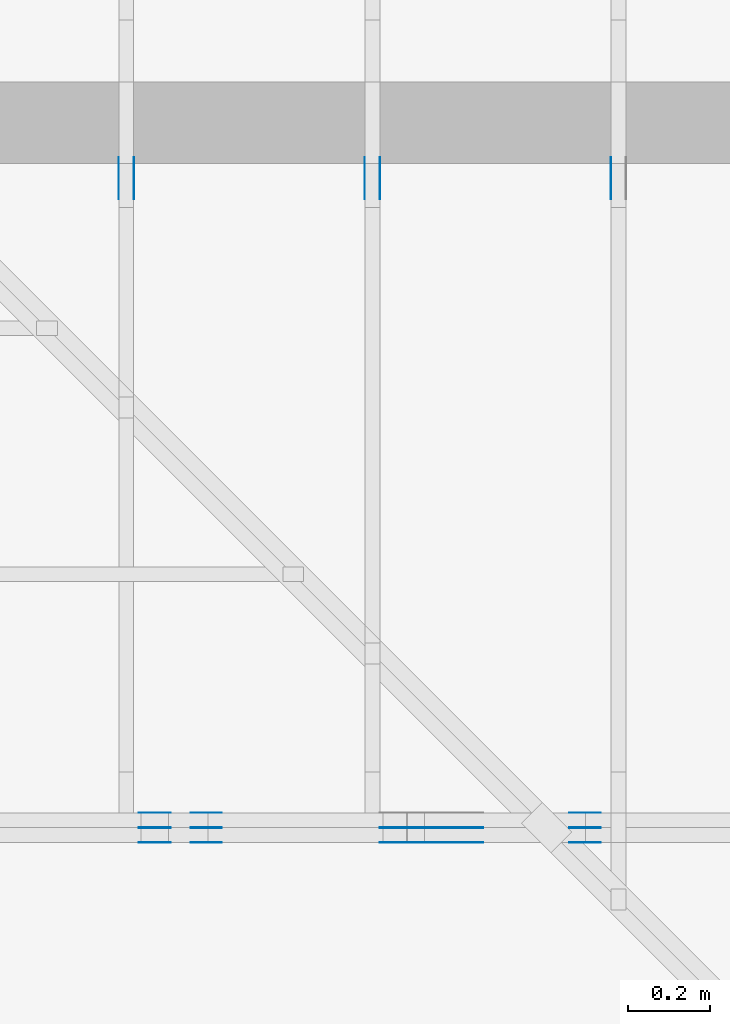
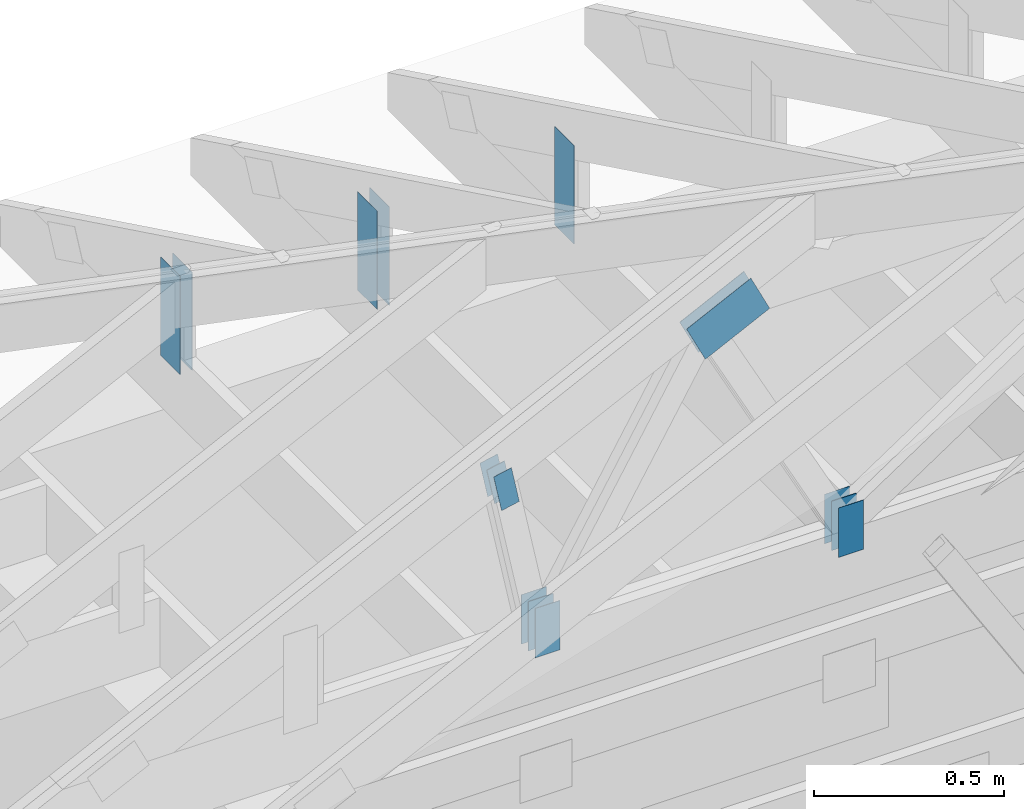
# One storey, part 109 of 159: 20 plates, 4 elements without a shape of their own.
"""IFC2X3 building model written with IfcOpenShell, lengths in millimetres."""

from ifc_helpers import new_model, si_unit, frame, origin, origin_with_axes, origin_2d, place, context, project, spatial, faceted_brep, element, aggregate, save


model = new_model("IFC2X3")

# Units and contexts
model_context = context("Model", 3, precision=1e-05, world=origin())
plan_context = context("Plan", 2, precision=1e-05, world=origin_2d())
ifc_project = project(units=[si_unit("LENGTHUNIT", "METRE", prefix="MILLI"), si_unit("AREAUNIT", "SQUARE_METRE"), si_unit("VOLUMEUNIT", "CUBIC_METRE"), si_unit("SOLIDANGLEUNIT", "STERADIAN"), si_unit("PLANEANGLEUNIT", "RADIAN"), si_unit("MASSUNIT", "GRAM"), si_unit("TIMEUNIT", "SECOND"), si_unit("THERMODYNAMICTEMPERATUREUNIT", "DEGREE_CELSIUS"), si_unit("LUMINOUSINTENSITYUNIT", "LUMEN")], contexts=[model_context, plan_context])

# Site, building, storey
site_placement = place(None, origin_with_axes())
site = spatial("IfcSite", under=ifc_project, at=site_placement, CompositionType="ELEMENT")
building_placement = place(site_placement, origin_with_axes())
building = spatial("IfcBuilding", under=site, at=building_placement, Name="Plan 1", CompositionType="ELEMENT")
storey_placement = place(building_placement, origin_with_axes())
storey = spatial("IfcBuildingStorey", under=building, at=storey_placement, Name="Etasje 1", CompositionType="ELEMENT", Elevation=0.0)

# Assembly, plates
assembly_1_placement = place(storey_placement, frame((19200.01266310149, 11417.999978540158, 0.0), z_axis=(1.2246063538223773e-16, 1.0, 6.123031769111886e-17), x_axis=(-1.0, 1.2246063538223773e-16, 0.0)))
assembly_1 = element("IfcElementAssembly", 1, at=assembly_1_placement, inside=storey, Name="V9 (1)", AssemblyPlace="FACTORY", PredefinedType="TRUSS")
plate_1_placement = place(assembly_1_placement, frame((7089.08254927267, 1040.5283812914454, -37.0), z_axis=(0.0, 0.0, 1.0), x_axis=(-0.8987940462991675, 0.4383711467890765, 0.0)))
plate_1 = element("IfcPlate", 2, at=plate_1_placement, Name="GNT100S 130x218", context=model_context, shape_type="Brep", body=[
    faceted_brep([(217.99994580165003, 130.0000591753469, 1.0), (4.001814977527829e-05, 130.0000591753469, 1.0), (0.0, 6.784529341530288e-05, 1.0), (217.999932539552, 6.784529341530288e-05, 1.0), (4.001814977527829e-05, 130.0000591753469, 4.900648048302133e-21), (217.99994580165003, 130.0000591753469, 2.669641187616345e-14), (217.999932539552, 0.0, 2.6696410252078497e-14), (0.0, 0.0, 0.0), (218.0001372720617, 0.00012490185868588963, 2.4519465511824615e-30), (218.0001372720617, 0.00012490185868595086, 1.0), (0.0001372720607832889, 0.0001249018587259955, 1.0), (0.0001372720607832889, 0.00012490185872593426, 1.504632769052528e-36), (218.0001372720617, 130.00012490185873, 0.0), (218.0001372720617, 130.00012490185873, 1.0), (218.0001372720617, 0.0001249018587259343, 1.0), (218.0001372720617, 0.0001249018587259343, 0.0), (0.0001372720616927836, 130.00012490185827, 0.0), (0.0001372720616927836, 130.00012490185827, 1.0), (218.0001372720617, 130.00012490185875, 1.0), (218.0001372720617, 130.00012490185875, 1.5777218104420236e-30), (0.00013727206078328883, 0.0001249018587259343, 4.513898307157584e-36), (0.00013727206078335006, 0.0001249018587259343, 1.0), (0.0001372720616075123, 130.00012490185827, 1.0), (0.00013727206160745107, 130.00012490185827, 5.22493810093043e-30)], [[[0, 1, 2, 3]], [[4, 5, 6, 7]], [[8, 9, 10, 11]], [[12, 13, 14, 15]], [[16, 17, 18, 19]], [[20, 21, 22, 23]]]),
])
plate_2_placement = place(assembly_1_placement, frame((7089.08254927267, 1040.5283812914454, -36.0), z_axis=(0.0, 0.0, 1.0), x_axis=(-0.8987940462991675, 0.4383711467890765, 0.0)))
plate_2 = element("IfcPlate", 3, at=plate_2_placement, Name="GNT100S 130x218", context=model_context, shape_type="Brep", body=[
    faceted_brep([(217.99994580165003, 130.0000591753469, 1.0), (4.001814977527829e-05, 130.0000591753469, 1.0), (0.0, 6.784529341530288e-05, 1.0), (217.999932539552, 6.784529341530288e-05, 1.0), (4.001814977527829e-05, 130.0000591753469, 4.900648048302133e-21), (217.99994580165003, 130.0000591753469, 2.669641187616345e-14), (217.999932539552, 0.0, 2.6696410252078497e-14), (0.0, 0.0, 0.0), (218.0001372720617, 0.00012490185868588963, 2.4519465511824615e-30), (218.0001372720617, 0.00012490185868595086, 1.0), (0.0001372720607832889, 0.0001249018587259955, 1.0), (0.0001372720607832889, 0.00012490185872593426, 1.504632769052528e-36), (218.0001372720617, 130.00012490185873, 0.0), (218.0001372720617, 130.00012490185873, 1.0), (218.0001372720617, 0.0001249018587259343, 1.0), (218.0001372720617, 0.0001249018587259343, 0.0), (0.0001372720616927836, 130.00012490185827, 0.0), (0.0001372720616927836, 130.00012490185827, 1.0), (218.0001372720617, 130.00012490185875, 1.0), (218.0001372720617, 130.00012490185875, 1.5777218104420236e-30), (0.00013727206078328883, 0.0001249018587259343, 4.513898307157584e-36), (0.00013727206078335006, 0.0001249018587259343, 1.0), (0.0001372720616075123, 130.00012490185827, 1.0), (0.00013727206160745107, 130.00012490185827, 5.22493810093043e-30)], [[[0, 1, 2, 3]], [[4, 5, 6, 7]], [[8, 9, 10, 11]], [[12, 13, 14, 15]], [[16, 17, 18, 19]], [[20, 21, 22, 23]]]),
])
plate_3_placement = place(assembly_1_placement, frame((7089.08254927267, 1040.5283812914454, -73.0), z_axis=(0.0, 0.0, 1.0), x_axis=(-0.8987940462991675, 0.4383711467890765, 0.0)))
plate_3 = element("IfcPlate", 4, at=plate_3_placement, Name="GNT100S 130x218", context=model_context, shape_type="Brep", body=[
    faceted_brep([(217.99994580165003, 130.0000591753469, 1.0), (4.001814977527829e-05, 130.0000591753469, 1.0), (0.0, 6.784529341530288e-05, 1.0), (217.999932539552, 6.784529341530288e-05, 1.0), (4.001814977527829e-05, 130.0000591753469, 4.900648048302133e-21), (217.99994580165003, 130.0000591753469, 2.669641187616345e-14), (217.999932539552, 0.0, 2.6696410252078497e-14), (0.0, 0.0, 0.0), (218.0001372720617, 0.00012490185868588963, 2.4519465511824615e-30), (218.0001372720617, 0.00012490185868595086, 1.0), (0.0001372720607832889, 0.0001249018587259955, 1.0), (0.0001372720607832889, 0.00012490185872593426, 1.504632769052528e-36), (218.0001372720617, 130.00012490185873, 0.0), (218.0001372720617, 130.00012490185873, 1.0), (218.0001372720617, 0.0001249018587259343, 1.0), (218.0001372720617, 0.0001249018587259343, 0.0), (0.0001372720616927836, 130.00012490185827, 0.0), (0.0001372720616927836, 130.00012490185827, 1.0), (218.0001372720617, 130.00012490185875, 1.0), (218.0001372720617, 130.00012490185875, 1.5777218104420236e-30), (0.00013727206078328883, 0.0001249018587259343, 4.513898307157584e-36), (0.00013727206078335006, 0.0001249018587259343, 1.0), (0.0001372720616075123, 130.00012490185827, 1.0), (0.00013727206160745107, 130.00012490185827, 5.22493810093043e-30)], [[[0, 1, 2, 3]], [[4, 5, 6, 7]], [[8, 9, 10, 11]], [[12, 13, 14, 15]], [[16, 17, 18, 19]], [[20, 21, 22, 23]]]),
])
plate_4_placement = place(assembly_1_placement, frame((6626.715981225386, 143.5, 0.0), z_axis=(0.0, 0.0, 1.0), x_axis=(6.123031769111886e-17, 1.0, 0.0)))
plate_4 = element("IfcPlate", 5, at=plate_4_placement, Name="GNT100S 76x159", context=model_context, shape_type="Brep", body=[
    faceted_brep([(159.0, 76.0001609128858, 1.0), (0.0, 76.0001609128858, 1.0), (0.0, 0.00016091288580355467, 1.0), (159.0, 0.00016091288580355467, 1.0), (0.0, 76.0001609128858, 0.0), (159.0, 76.0001609128858, 1.9471241025775798e-14), (159.0, 0.00016091288580355467, 1.9471241025775798e-14), (0.0, 0.00016091288580355467, 0.0), (159.00000000000023, -2.920686153866374e-14, 1.7883454107729013e-30), (159.00000000000023, -2.914563122097262e-14, 1.0), (1.9895196601282805e-13, 6.123031769108232e-17, 1.0), (1.9895196601282805e-13, -3.654567625271443e-29, 2.237703367190483e-45), (159.00000000000023, 76.0, 0.0), (159.00000000000023, 76.0, 1.0), (159.00000000000023, 0.0, 1.0), (159.00000000000023, 0.0, 0.0), (1.9895196601282805e-13, 76.0, 0.0), (1.9895196601282805e-13, 76.0, 1.0), (159.00000000000023, 75.99999999999999, 1.0), (159.00000000000023, 75.99999999999999, -7.888609052210118e-31), (1.9895196601282805e-13, 0.0, 0.0), (1.9901319633051917e-13, -7.498303609110687e-33, 1.0), (2.0832020461956924e-13, 76.0, 1.0), (2.0825897430187812e-13, 76.0, -5.698710742924122e-31)], [[[0, 1, 2, 3]], [[4, 5, 6, 7]], [[8, 9, 10, 11]], [[12, 13, 14, 15]], [[16, 17, 18, 19]], [[20, 21, 22, 23]]]),
])
plate_5_placement = place(assembly_1_placement, frame((6626.715981225386, 143.5, -37.0), z_axis=(0.0, 0.0, 1.0), x_axis=(6.123031769111886e-17, 1.0, 0.0)))
plate_5 = element("IfcPlate", 6, at=plate_5_placement, Name="GNT100S 76x159", context=model_context, shape_type="Brep", body=[
    faceted_brep([(159.0, 76.0001609128858, 1.0), (0.0, 76.0001609128858, 1.0), (0.0, 0.00016091288580355467, 1.0), (159.0, 0.00016091288580355467, 1.0), (0.0, 76.0001609128858, 0.0), (159.0, 76.0001609128858, 1.9471241025775798e-14), (159.0, 0.00016091288580355467, 1.9471241025775798e-14), (0.0, 0.00016091288580355467, 0.0), (159.00000000000023, -2.920686153866374e-14, 1.7883454107729013e-30), (159.00000000000023, -2.914563122097262e-14, 1.0), (1.9895196601282805e-13, 6.123031769108232e-17, 1.0), (1.9895196601282805e-13, -3.654567625271443e-29, 2.237703367190483e-45), (159.00000000000023, 76.0, 0.0), (159.00000000000023, 76.0, 1.0), (159.00000000000023, 0.0, 1.0), (159.00000000000023, 0.0, 0.0), (1.9895196601282805e-13, 76.0, 0.0), (1.9895196601282805e-13, 76.0, 1.0), (159.00000000000023, 75.99999999999999, 1.0), (159.00000000000023, 75.99999999999999, -7.888609052210118e-31), (1.9895196601282805e-13, 0.0, 0.0), (1.9901319633051917e-13, -7.498303609110687e-33, 1.0), (2.0832020461956924e-13, 76.0, 1.0), (2.0825897430187812e-13, 76.0, -5.698710742924122e-31)], [[[0, 1, 2, 3]], [[4, 5, 6, 7]], [[8, 9, 10, 11]], [[12, 13, 14, 15]], [[16, 17, 18, 19]], [[20, 21, 22, 23]]]),
])
plate_6_placement = place(assembly_1_placement, frame((6626.715981225386, 143.5, -36.0), z_axis=(0.0, 0.0, 1.0), x_axis=(6.123031769111886e-17, 1.0, 0.0)))
plate_6 = element("IfcPlate", 7, at=plate_6_placement, Name="GNT100S 76x159", context=model_context, shape_type="Brep", body=[
    faceted_brep([(159.0, 76.0001609128858, 1.0), (0.0, 76.0001609128858, 1.0), (0.0, 0.00016091288580355467, 1.0), (159.0, 0.00016091288580355467, 1.0), (0.0, 76.0001609128858, 0.0), (159.0, 76.0001609128858, 1.9471241025775798e-14), (159.0, 0.00016091288580355467, 1.9471241025775798e-14), (0.0, 0.00016091288580355467, 0.0), (159.00000000000023, -2.920686153866374e-14, 1.7883454107729013e-30), (159.00000000000023, -2.914563122097262e-14, 1.0), (1.9895196601282805e-13, 6.123031769108232e-17, 1.0), (1.9895196601282805e-13, -3.654567625271443e-29, 2.237703367190483e-45), (159.00000000000023, 76.0, 0.0), (159.00000000000023, 76.0, 1.0), (159.00000000000023, 0.0, 1.0), (159.00000000000023, 0.0, 0.0), (1.9895196601282805e-13, 76.0, 0.0), (1.9895196601282805e-13, 76.0, 1.0), (159.00000000000023, 75.99999999999999, 1.0), (159.00000000000023, 75.99999999999999, -7.888609052210118e-31), (1.9895196601282805e-13, 0.0, 0.0), (1.9901319633051917e-13, -7.498303609110687e-33, 1.0), (2.0832020461956924e-13, 76.0, 1.0), (2.0825897430187812e-13, 76.0, -5.698710742924122e-31)], [[[0, 1, 2, 3]], [[4, 5, 6, 7]], [[8, 9, 10, 11]], [[12, 13, 14, 15]], [[16, 17, 18, 19]], [[20, 21, 22, 23]]]),
])
plate_7_placement = place(assembly_1_placement, frame((6626.715981225386, 143.5, -73.0), z_axis=(0.0, 0.0, 1.0), x_axis=(6.123031769111886e-17, 1.0, 0.0)))
plate_7 = element("IfcPlate", 8, at=plate_7_placement, Name="GNT100S 76x159", context=model_context, shape_type="Brep", body=[
    faceted_brep([(159.0, 76.0001609128858, 1.0), (0.0, 76.0001609128858, 1.0), (0.0, 0.00016091288580355467, 1.0), (159.0, 0.00016091288580355467, 1.0), (0.0, 76.0001609128858, 0.0), (159.0, 76.0001609128858, 1.9471241025775798e-14), (159.0, 0.00016091288580355467, 1.9471241025775798e-14), (0.0, 0.00016091288580355467, 0.0), (159.00000000000023, -2.920686153866374e-14, 1.7883454107729013e-30), (159.00000000000023, -2.914563122097262e-14, 1.0), (1.9895196601282805e-13, 6.123031769108232e-17, 1.0), (1.9895196601282805e-13, -3.654567625271443e-29, 2.237703367190483e-45), (159.00000000000023, 76.0, 0.0), (159.00000000000023, 76.0, 1.0), (159.00000000000023, 0.0, 1.0), (159.00000000000023, 0.0, 0.0), (1.9895196601282805e-13, 76.0, 0.0), (1.9895196601282805e-13, 76.0, 1.0), (159.00000000000023, 75.99999999999999, 1.0), (159.00000000000023, 75.99999999999999, -7.888609052210118e-31), (1.9895196601282805e-13, 0.0, 0.0), (1.9901319633051917e-13, -7.498303609110687e-33, 1.0), (2.0832020461956924e-13, 76.0, 1.0), (2.0825897430187812e-13, 76.0, -5.698710742924122e-31)], [[[0, 1, 2, 3]], [[4, 5, 6, 7]], [[8, 9, 10, 11]], [[12, 13, 14, 15]], [[16, 17, 18, 19]], [[20, 21, 22, 23]]]),
])
plate_8_placement = place(assembly_1_placement, frame((7622.63964936509, 781.1871383023358, 0.0), z_axis=(0.0, 0.0, 1.0), x_axis=(-0.20131671299269083, -0.9795262023395898, 0.0)))
plate_8 = element("IfcPlate", 9, at=plate_8_placement, Name="GNT100S 55x119", context=model_context, shape_type="Brep", body=[
    faceted_brep([(118.99996853400717, 55.000086565686615, 1.0), (1.694903539828374e-05, 55.000086565686615, 1.0), (4.6076083890511654e-06, 0.0, 1.0), (119.00001597811479, 0.0, 1.0), (1.694903539828374e-05, 55.000086565686615, 2.0755896439898655e-21), (118.99996853400717, 55.000086565686615, 1.4572811757140815e-14), (119.00001597811479, 0.00015126338894333458, 1.457281756717638e-14), (4.6076083890511654e-06, 0.00015126338894333458, 5.642506509157345e-22), (119.0, 0.0001107744828278256, 3.89446958416127e-30), (119.0, 0.00011077448282788684, 1.0), (5.007417855406813e-31, 0.00011077448380098515, 1.0), (0.0, 0.00011077448380092392, 0.0), (119.0, 55.0001107744838, 0.0), (119.0, 55.0001107744838, 1.0), (119.0, 0.00011077448289142922, 1.0), (119.0, 0.00011077448289142922, 0.0), (0.0, 55.0001107744838, 0.0), (-3.7491518045553436e-33, 55.0001107744838, 1.0), (119.0, 55.000110774483794, 1.0), (119.0, 55.000110774483794, -3.944304526105059e-31), (1.3565513670400543e-20, 0.00011077448380092392, -8.306207116818412e-37), (6.124388320478926e-17, 0.00011077448380092392, 1.0), (6.7965788292278644e-15, 55.0001107744838, 1.0), (6.7353485115367456e-15, 55.0001107744838, -4.124075291217995e-31)], [[[0, 1, 2, 3]], [[4, 5, 6, 7]], [[8, 9, 10, 11]], [[12, 13, 14, 15]], [[16, 17, 18, 19]], [[20, 21, 22, 23]]]),
])
plate_9_placement = place(assembly_1_placement, frame((7622.63964936509, 781.1871383023358, -37.00000000000001), z_axis=(0.0, 0.0, 1.0), x_axis=(-0.20131671299269083, -0.9795262023395898, 0.0)))
plate_9 = element("IfcPlate", 10, at=plate_9_placement, Name="GNT100S 55x119", context=model_context, shape_type="Brep", body=[
    faceted_brep([(118.99996853400717, 55.000086565686615, 1.0), (1.694903539828374e-05, 55.000086565686615, 1.0), (4.6076083890511654e-06, 0.0, 1.0), (119.00001597811479, 0.0, 1.0), (1.694903539828374e-05, 55.000086565686615, 2.0755896439898655e-21), (118.99996853400717, 55.000086565686615, 1.4572811757140815e-14), (119.00001597811479, 0.00015126338894333458, 1.457281756717638e-14), (4.6076083890511654e-06, 0.00015126338894333458, 5.642506509157345e-22), (119.0, 0.0001107744828278256, 3.89446958416127e-30), (119.0, 0.00011077448282788684, 1.0), (5.007417855406813e-31, 0.00011077448380098515, 1.0), (0.0, 0.00011077448380092392, 0.0), (119.0, 55.0001107744838, 0.0), (119.0, 55.0001107744838, 1.0), (119.0, 0.00011077448289142922, 1.0), (119.0, 0.00011077448289142922, 0.0), (0.0, 55.0001107744838, 0.0), (-3.7491518045553436e-33, 55.0001107744838, 1.0), (119.0, 55.000110774483794, 1.0), (119.0, 55.000110774483794, -3.944304526105059e-31), (1.3565513670400543e-20, 0.00011077448380092392, -8.306207116818412e-37), (6.124388320478926e-17, 0.00011077448380092392, 1.0), (6.7965788292278644e-15, 55.0001107744838, 1.0), (6.7353485115367456e-15, 55.0001107744838, -4.124075291217995e-31)], [[[0, 1, 2, 3]], [[4, 5, 6, 7]], [[8, 9, 10, 11]], [[12, 13, 14, 15]], [[16, 17, 18, 19]], [[20, 21, 22, 23]]]),
])
plate_10_placement = place(assembly_1_placement, frame((7622.63964936509, 781.1871383023358, -36.00000000000001), z_axis=(0.0, 0.0, 1.0), x_axis=(-0.20131671299269083, -0.9795262023395898, 0.0)))
plate_10 = element("IfcPlate", 11, at=plate_10_placement, Name="GNT100S 55x119", context=model_context, shape_type="Brep", body=[
    faceted_brep([(118.99996853400717, 55.000086565686615, 1.0), (1.694903539828374e-05, 55.000086565686615, 1.0), (4.6076083890511654e-06, 0.0, 1.0), (119.00001597811479, 0.0, 1.0), (1.694903539828374e-05, 55.000086565686615, 2.0755896439898655e-21), (118.99996853400717, 55.000086565686615, 1.4572811757140815e-14), (119.00001597811479, 0.00015126338894333458, 1.457281756717638e-14), (4.6076083890511654e-06, 0.00015126338894333458, 5.642506509157345e-22), (119.0, 0.0001107744828278256, 3.89446958416127e-30), (119.0, 0.00011077448282788684, 1.0), (5.007417855406813e-31, 0.00011077448380098515, 1.0), (0.0, 0.00011077448380092392, 0.0), (119.0, 55.0001107744838, 0.0), (119.0, 55.0001107744838, 1.0), (119.0, 0.00011077448289142922, 1.0), (119.0, 0.00011077448289142922, 0.0), (0.0, 55.0001107744838, 0.0), (-3.7491518045553436e-33, 55.0001107744838, 1.0), (119.0, 55.000110774483794, 1.0), (119.0, 55.000110774483794, -3.944304526105059e-31), (1.3565513670400543e-20, 0.00011077448380092392, -8.306207116818412e-37), (6.124388320478926e-17, 0.00011077448380092392, 1.0), (6.7965788292278644e-15, 55.0001107744838, 1.0), (6.7353485115367456e-15, 55.0001107744838, -4.124075291217995e-31)], [[[0, 1, 2, 3]], [[4, 5, 6, 7]], [[8, 9, 10, 11]], [[12, 13, 14, 15]], [[16, 17, 18, 19]], [[20, 21, 22, 23]]]),
])
plate_11_placement = place(assembly_1_placement, frame((7622.63964936509, 781.1871383023358, -73.00000000000001), z_axis=(0.0, 0.0, 1.0), x_axis=(-0.20131671299269083, -0.9795262023395898, 0.0)))
plate_11 = element("IfcPlate", 12, at=plate_11_placement, Name="GNT100S 55x119", context=model_context, shape_type="Brep", body=[
    faceted_brep([(118.99996853400717, 55.000086565686615, 1.0), (1.694903539828374e-05, 55.000086565686615, 1.0), (4.6076083890511654e-06, 0.0, 1.0), (119.00001597811479, 0.0, 1.0), (1.694903539828374e-05, 55.000086565686615, 2.0755896439898655e-21), (118.99996853400717, 55.000086565686615, 1.4572811757140815e-14), (119.00001597811479, 0.00015126338894333458, 1.457281756717638e-14), (4.6076083890511654e-06, 0.00015126338894333458, 5.642506509157345e-22), (119.0, 0.0001107744828278256, 3.89446958416127e-30), (119.0, 0.00011077448282788684, 1.0), (5.007417855406813e-31, 0.00011077448380098515, 1.0), (0.0, 0.00011077448380092392, 0.0), (119.0, 55.0001107744838, 0.0), (119.0, 55.0001107744838, 1.0), (119.0, 0.00011077448289142922, 1.0), (119.0, 0.00011077448289142922, 0.0), (0.0, 55.0001107744838, 0.0), (-3.7491518045553436e-33, 55.0001107744838, 1.0), (119.0, 55.000110774483794, 1.0), (119.0, 55.000110774483794, -3.944304526105059e-31), (1.3565513670400543e-20, 0.00011077448380092392, -8.306207116818412e-37), (6.124388320478926e-17, 0.00011077448380092392, 1.0), (6.7965788292278644e-15, 55.0001107744838, 1.0), (6.7353485115367456e-15, 55.0001107744838, -4.124075291217995e-31)], [[[0, 1, 2, 3]], [[4, 5, 6, 7]], [[8, 9, 10, 11]], [[12, 13, 14, 15]], [[16, 17, 18, 19]], [[20, 21, 22, 23]]]),
])
plate_12_placement = place(assembly_1_placement, frame((7550.1728515625, 143.4999999999986, 0.0), z_axis=(0.0, 0.0, 1.0), x_axis=(6.123031769111886e-17, 1.0, 0.0)))
plate_12 = element("IfcPlate", 13, at=plate_12_placement, Name="GNT100S 76x159", context=model_context, shape_type="Brep", body=[
    faceted_brep([(159.0000000000014, 76.0, 1.0), (1.3926637620897964e-12, 76.0, 1.0), (1.3926637620897964e-12, 0.0, 1.0), (159.0000000000014, 0.0, 1.0), (1.3926637620897964e-12, 76.0, 1.7054648917933402e-28), (159.0000000000014, 76.0, 1.947124102577597e-14), (159.0000000000014, 0.0, 1.947124102577597e-14), (1.3926637620897964e-12, 0.0, 1.7054648917933402e-28), (159.00000000000003, 0.000135123323132472, 1.7883448193523036e-30), (159.00000000000003, 0.00013512332313253322, 1.0), (1.1247455413666031e-32, 0.00013512332316174008, 1.0), (0.0, 0.00013512332316167885, 0.0), (159.00000000000003, 76.00013512332316, 0.0), (159.00000000000003, 76.00013512332316, 1.0), (159.00000000000003, 0.00013512332316167885, 1.0), (159.00000000000003, 0.00013512332316167885, 0.0), (0.0, 76.00013512332316, 0.0), (-3.7491518045553436e-33, 76.00013512332316, 1.0), (159.00000000000003, 76.00013512332315, 1.0), (159.00000000000003, 76.00013512332315, -7.888609052210118e-31), (1.6547288009338632e-20, 0.00013512332316167885, -1.0131957017382463e-36), (6.12468649791282e-17, 0.00013512332316167885, 1.0), (9.368255154029196e-15, 76.00013512332316, 1.0), (9.307024836338077e-15, 76.00013512332316, -5.69872087488114e-31)], [[[0, 1, 2, 3]], [[4, 5, 6, 7]], [[8, 9, 10, 11]], [[12, 13, 14, 15]], [[16, 17, 18, 19]], [[20, 21, 22, 23]]]),
])
plate_13_placement = place(assembly_1_placement, frame((7550.1728515625, 143.4999999999986, -37.0), z_axis=(0.0, 0.0, 1.0), x_axis=(6.123031769111886e-17, 1.0, 0.0)))
plate_13 = element("IfcPlate", 14, at=plate_13_placement, Name="GNT100S 76x159", context=model_context, shape_type="Brep", body=[
    faceted_brep([(159.0000000000014, 76.0, 1.0), (1.3926637620897964e-12, 76.0, 1.0), (1.3926637620897964e-12, 0.0, 1.0), (159.0000000000014, 0.0, 1.0), (1.3926637620897964e-12, 76.0, 1.7054648917933402e-28), (159.0000000000014, 76.0, 1.947124102577597e-14), (159.0000000000014, 0.0, 1.947124102577597e-14), (1.3926637620897964e-12, 0.0, 1.7054648917933402e-28), (159.00000000000003, 0.000135123323132472, 1.7883448193523036e-30), (159.00000000000003, 0.00013512332313253322, 1.0), (1.1247455413666031e-32, 0.00013512332316174008, 1.0), (0.0, 0.00013512332316167885, 0.0), (159.00000000000003, 76.00013512332316, 0.0), (159.00000000000003, 76.00013512332316, 1.0), (159.00000000000003, 0.00013512332316167885, 1.0), (159.00000000000003, 0.00013512332316167885, 0.0), (0.0, 76.00013512332316, 0.0), (-3.7491518045553436e-33, 76.00013512332316, 1.0), (159.00000000000003, 76.00013512332315, 1.0), (159.00000000000003, 76.00013512332315, -7.888609052210118e-31), (1.6547288009338632e-20, 0.00013512332316167885, -1.0131957017382463e-36), (6.12468649791282e-17, 0.00013512332316167885, 1.0), (9.368255154029196e-15, 76.00013512332316, 1.0), (9.307024836338077e-15, 76.00013512332316, -5.69872087488114e-31)], [[[0, 1, 2, 3]], [[4, 5, 6, 7]], [[8, 9, 10, 11]], [[12, 13, 14, 15]], [[16, 17, 18, 19]], [[20, 21, 22, 23]]]),
])
plate_14_placement = place(assembly_1_placement, frame((7550.1728515625, 143.4999999999986, -36.0), z_axis=(0.0, 0.0, 1.0), x_axis=(6.123031769111886e-17, 1.0, 0.0)))
plate_14 = element("IfcPlate", 15, at=plate_14_placement, Name="GNT100S 76x159", context=model_context, shape_type="Brep", body=[
    faceted_brep([(159.0000000000014, 76.0, 1.0), (1.3926637620897964e-12, 76.0, 1.0), (1.3926637620897964e-12, 0.0, 1.0), (159.0000000000014, 0.0, 1.0), (1.3926637620897964e-12, 76.0, 1.7054648917933402e-28), (159.0000000000014, 76.0, 1.947124102577597e-14), (159.0000000000014, 0.0, 1.947124102577597e-14), (1.3926637620897964e-12, 0.0, 1.7054648917933402e-28), (159.00000000000003, 0.000135123323132472, 1.7883448193523036e-30), (159.00000000000003, 0.00013512332313253322, 1.0), (1.1247455413666031e-32, 0.00013512332316174008, 1.0), (0.0, 0.00013512332316167885, 0.0), (159.00000000000003, 76.00013512332316, 0.0), (159.00000000000003, 76.00013512332316, 1.0), (159.00000000000003, 0.00013512332316167885, 1.0), (159.00000000000003, 0.00013512332316167885, 0.0), (0.0, 76.00013512332316, 0.0), (-3.7491518045553436e-33, 76.00013512332316, 1.0), (159.00000000000003, 76.00013512332315, 1.0), (159.00000000000003, 76.00013512332315, -7.888609052210118e-31), (1.6547288009338632e-20, 0.00013512332316167885, -1.0131957017382463e-36), (6.12468649791282e-17, 0.00013512332316167885, 1.0), (9.368255154029196e-15, 76.00013512332316, 1.0), (9.307024836338077e-15, 76.00013512332316, -5.69872087488114e-31)], [[[0, 1, 2, 3]], [[4, 5, 6, 7]], [[8, 9, 10, 11]], [[12, 13, 14, 15]], [[16, 17, 18, 19]], [[20, 21, 22, 23]]]),
])
plate_15_placement = place(assembly_1_placement, frame((7550.1728515625, 143.4999999999986, -73.0), z_axis=(0.0, 0.0, 1.0), x_axis=(6.123031769111886e-17, 1.0, 0.0)))
plate_15 = element("IfcPlate", 16, at=plate_15_placement, Name="GNT100S 76x159", context=model_context, shape_type="Brep", body=[
    faceted_brep([(159.0000000000014, 76.0, 1.0), (1.3926637620897964e-12, 76.0, 1.0), (1.3926637620897964e-12, 0.0, 1.0), (159.0000000000014, 0.0, 1.0), (1.3926637620897964e-12, 76.0, 1.7054648917933402e-28), (159.0000000000014, 76.0, 1.947124102577597e-14), (159.0000000000014, 0.0, 1.947124102577597e-14), (1.3926637620897964e-12, 0.0, 1.7054648917933402e-28), (159.00000000000003, 0.000135123323132472, 1.7883448193523036e-30), (159.00000000000003, 0.00013512332313253322, 1.0), (1.1247455413666031e-32, 0.00013512332316174008, 1.0), (0.0, 0.00013512332316167885, 0.0), (159.00000000000003, 76.00013512332316, 0.0), (159.00000000000003, 76.00013512332316, 1.0), (159.00000000000003, 0.00013512332316167885, 1.0), (159.00000000000003, 0.00013512332316167885, 0.0), (0.0, 76.00013512332316, 0.0), (-3.7491518045553436e-33, 76.00013512332316, 1.0), (159.00000000000003, 76.00013512332315, 1.0), (159.00000000000003, 76.00013512332315, -7.888609052210118e-31), (1.6547288009338632e-20, 0.00013512332316167885, -1.0131957017382463e-36), (6.12468649791282e-17, 0.00013512332316167885, 1.0), (9.368255154029196e-15, 76.00013512332316, 1.0), (9.307024836338077e-15, 76.00013512332316, -5.69872087488114e-31)], [[[0, 1, 2, 3]], [[4, 5, 6, 7]], [[8, 9, 10, 11]], [[12, 13, 14, 15]], [[16, 17, 18, 19]], [[20, 21, 22, 23]]]),
])
aggregate(assembly_1, [plate_1, plate_2, plate_3, plate_4, plate_5, plate_6, plate_7, plate_8, plate_9, plate_10, plate_11, plate_12, plate_13, plate_14, plate_15])

assembly_2_placement = place(storey_placement, frame((12075.022261404758, 13899.999978540158, 1.1021457184401395e-15), z_axis=(-1.0, 1.836909530733566e-16, 6.123031769111886e-17), x_axis=(-1.836909530733566e-16, -1.0, 0.0)))
assembly_2 = element("IfcElementAssembly", 17, at=assembly_2_placement, inside=storey, Name="S32 (63)", AssemblyPlace="FACTORY", PredefinedType="TRUSS")
plate_16_placement = place(assembly_2_placement, frame((986.0125131976824, 165.43966674804688, 0.0), z_axis=(0.0, 0.0, 1.0), x_axis=(6.123031769111886e-17, 1.0, 0.0)))
plate_16 = element("IfcPlate", 18, at=plate_16_placement, Name="GNT100S 103x317", context=model_context, shape_type="Brep", body=[
    faceted_brep([(317.0, 103.00000099065119, 1.0), (0.0, 103.00000099065119, 1.0), (0.0, 9.90651187748881e-07, 1.0), (317.0, 9.90651187748881e-07, 1.0), (0.0, 103.00000099065119, 0.0), (317.0, 103.00000099065119, 3.882002141616936e-14), (317.0, 9.90651187748881e-07, 3.882002141616936e-14), (0.0, 9.90651187748881e-07, 0.0), (317.00000586351644, -5.823003320132896e-14, 3.5654434320817714e-30), (317.00000586351644, -5.816880288363784e-14, 1.0), (5.863516435056226e-06, 6.122924061619655e-17, 1.0), (5.863516435056226e-06, -1.0770749223167684e-21, 6.59496396705929e-38), (317.00000586351644, 103.0, 0.0), (317.00000586351644, 103.0, 1.0), (317.00000586351644, 0.0, 1.0), (317.00000586351644, 0.0, 0.0), (5.863516435056226e-06, 103.0, 0.0), (5.863516435056226e-06, 103.0, 1.0), (317.00000586351644, 102.99999999999999, 1.0), (317.00000586351644, 102.99999999999999, -1.5777218104420236e-30), (5.863516435056226e-06, 0.0, 0.0), (5.863516435117457e-06, -7.498303609110687e-33, 1.0), (5.863516447730902e-06, 103.0, 1.0), (5.863516447669672e-06, 103.0, -7.723252732077687e-31)], [[[0, 1, 2, 3]], [[4, 5, 6, 7]], [[8, 9, 10, 11]], [[12, 13, 14, 15]], [[16, 17, 18, 19]], [[20, 21, 22, 23]]]),
])
plate_17_placement = place(assembly_2_placement, frame((986.0125131976824, 165.43966674804688, -37.0), z_axis=(0.0, 0.0, 1.0), x_axis=(6.123031769111886e-17, 1.0, 0.0)))
plate_17 = element("IfcPlate", 19, at=plate_17_placement, Name="GNT100S 103x317", context=model_context, shape_type="Brep", body=[
    faceted_brep([(317.0, 103.00000099065119, 1.0), (0.0, 103.00000099065119, 1.0), (0.0, 9.90651187748881e-07, 1.0), (317.0, 9.90651187748881e-07, 1.0), (0.0, 103.00000099065119, 0.0), (317.0, 103.00000099065119, 3.882002141616936e-14), (317.0, 9.90651187748881e-07, 3.882002141616936e-14), (0.0, 9.90651187748881e-07, 0.0), (317.00000586351644, -5.823003320132896e-14, 3.5654434320817714e-30), (317.00000586351644, -5.816880288363784e-14, 1.0), (5.863516435056226e-06, 6.122924061619655e-17, 1.0), (5.863516435056226e-06, -1.0770749223167684e-21, 6.59496396705929e-38), (317.00000586351644, 103.0, 0.0), (317.00000586351644, 103.0, 1.0), (317.00000586351644, 0.0, 1.0), (317.00000586351644, 0.0, 0.0), (5.863516435056226e-06, 103.0, 0.0), (5.863516435056226e-06, 103.0, 1.0), (317.00000586351644, 102.99999999999999, 1.0), (317.00000586351644, 102.99999999999999, -1.5777218104420236e-30), (5.863516435056226e-06, 0.0, 0.0), (5.863516435117457e-06, -7.498303609110687e-33, 1.0), (5.863516447730902e-06, 103.0, 1.0), (5.863516447669672e-06, 103.0, -7.723252732077687e-31)], [[[0, 1, 2, 3]], [[4, 5, 6, 7]], [[8, 9, 10, 11]], [[12, 13, 14, 15]], [[16, 17, 18, 19]], [[20, 21, 22, 23]]]),
])
aggregate(assembly_2, [plate_16, plate_17])

# Assembly, plate
assembly_3_placement = place(storey_placement, frame((12675.022261404758, 13899.999978540158, 1.1021457184401395e-15), z_axis=(-1.0, 1.836909530733566e-16, 6.123031769111886e-17), x_axis=(-1.836909530733566e-16, -1.0, 0.0)))
assembly_3 = element("IfcElementAssembly", 20, at=assembly_3_placement, inside=storey, Name="S33 (69)", AssemblyPlace="FACTORY", PredefinedType="TRUSS")
plate_18_placement = place(assembly_3_placement, frame((986.0125131970744, 165.43966674804688, 0.0), z_axis=(0.0, 0.0, 1.0), x_axis=(6.123031769111886e-17, 1.0, 0.0)))
plate_18 = element("IfcPlate", 21, at=plate_18_placement, Name="GNT100S 103x317", context=model_context, shape_type="Brep", body=[
    faceted_brep([(317.0, 103.00000099004319, 1.0), (0.0, 103.00000099004319, 1.0), (0.0, 9.900431905407459e-07, 1.0), (317.0, 9.900431905407459e-07, 1.0), (0.0, 103.00000099004319, 0.0), (317.0, 103.00000099004319, 3.882002141616936e-14), (317.0, 9.900431905407459e-07, 3.882002141616936e-14), (0.0, 9.900431905407459e-07, 0.0), (317.0000058634071, -5.823003320130888e-14, 3.565443432080542e-30), (317.0000058634071, -5.816880288361776e-14, 1.0), (5.863407125161757e-06, 6.122924063627578e-17, 1.0), (5.863407125161757e-06, -1.077054843078073e-21, 6.594841021242858e-38), (317.0000058634071, 103.0, 0.0), (317.0000058634071, 103.0, 1.0), (317.0000058634071, 0.0, 1.0), (317.0000058634071, 0.0, 0.0), (5.863407125161757e-06, 103.0, 0.0), (5.863407125161757e-06, 103.0, 1.0), (317.0000058634071, 102.99999999999999, 1.0), (317.0000058634071, 102.99999999999999, -1.5777218104420236e-30), (5.863407125161757e-06, 0.0, 0.0), (5.863407125222987e-06, -7.498303609110687e-33, 1.0), (5.863407137836433e-06, 103.0, 1.0), (5.8634071377752024e-06, 103.0, -7.723252732077687e-31)], [[[0, 1, 2, 3]], [[4, 5, 6, 7]], [[8, 9, 10, 11]], [[12, 13, 14, 15]], [[16, 17, 18, 19]], [[20, 21, 22, 23]]]),
])
aggregate(assembly_3, [plate_18])

# Assembly, plates
assembly_4_placement = place(storey_placement, frame((11475.022261404758, 13899.999978540158, 1.1021457184401395e-15), z_axis=(-1.0, 1.836909530733566e-16, 6.123031769111886e-17), x_axis=(-1.836909530733566e-16, -1.0, 0.0)))
assembly_4 = element("IfcElementAssembly", 22, at=assembly_4_placement, inside=storey, Name="S31 (70)", AssemblyPlace="FACTORY", PredefinedType="TRUSS")
plate_19_placement = place(assembly_4_placement, frame((986.0125131972059, 165.43966674804688, 0.0), z_axis=(0.0, 0.0, 1.0), x_axis=(6.123031769111886e-17, 1.0, 0.0)))
plate_19 = element("IfcPlate", 23, at=plate_19_placement, Name="GNT100S 103x317", context=model_context, shape_type="Brep", body=[
    faceted_brep([(317.0, 103.00000099017461, 1.0), (0.0, 103.00000099017461, 1.0), (0.0, 9.90174612525152e-07, 1.0), (317.0, 9.90174612525152e-07, 1.0), (0.0, 103.00000099017461, 0.0), (317.0, 103.00000099017461, 3.882002141616936e-14), (317.0, 9.90174612525152e-07, 3.882002141616936e-14), (0.0, 9.90174612525152e-07, 0.0), (317.0000058631723, -5.823003320126575e-14, 3.565443432077901e-30), (317.0000058631723, -5.816880288357463e-14, 1.0), (5.863172304998443e-06, 6.122924067941013e-17, 1.0), (5.863172304998443e-06, -1.077011708738473e-21, 6.594576908311148e-38), (317.0000058631723, 103.0, 0.0), (317.0000058631723, 103.0, 1.0), (317.0000058631723, 0.0, 1.0), (317.0000058631723, 0.0, 0.0), (5.863172304998443e-06, 103.0, 0.0), (5.863172304998443e-06, 103.0, 1.0), (317.0000058631723, 102.99999999999999, 1.0), (317.0000058631723, 102.99999999999999, -1.5777218104420236e-30), (5.863172304998443e-06, 0.0, 0.0), (5.863172305059673e-06, -7.498303609110687e-33, 1.0), (5.863172317673119e-06, 103.0, 1.0), (5.8631723176118884e-06, 103.0, -7.723252732077687e-31)], [[[0, 1, 2, 3]], [[4, 5, 6, 7]], [[8, 9, 10, 11]], [[12, 13, 14, 15]], [[16, 17, 18, 19]], [[20, 21, 22, 23]]]),
])
plate_20_placement = place(assembly_4_placement, frame((986.0125131972059, 165.43966674804688, -37.0), z_axis=(0.0, 0.0, 1.0), x_axis=(6.123031769111886e-17, 1.0, 0.0)))
plate_20 = element("IfcPlate", 24, at=plate_20_placement, Name="GNT100S 103x317", context=model_context, shape_type="Brep", body=[
    faceted_brep([(317.0, 103.00000099017461, 1.0), (0.0, 103.00000099017461, 1.0), (0.0, 9.90174612525152e-07, 1.0), (317.0, 9.90174612525152e-07, 1.0), (0.0, 103.00000099017461, 0.0), (317.0, 103.00000099017461, 3.882002141616936e-14), (317.0, 9.90174612525152e-07, 3.882002141616936e-14), (0.0, 9.90174612525152e-07, 0.0), (317.0000058631723, -5.823003320126575e-14, 3.565443432077901e-30), (317.0000058631723, -5.816880288357463e-14, 1.0), (5.863172304998443e-06, 6.122924067941013e-17, 1.0), (5.863172304998443e-06, -1.077011708738473e-21, 6.594576908311148e-38), (317.0000058631723, 103.0, 0.0), (317.0000058631723, 103.0, 1.0), (317.0000058631723, 0.0, 1.0), (317.0000058631723, 0.0, 0.0), (5.863172304998443e-06, 103.0, 0.0), (5.863172304998443e-06, 103.0, 1.0), (317.0000058631723, 102.99999999999999, 1.0), (317.0000058631723, 102.99999999999999, -1.5777218104420236e-30), (5.863172304998443e-06, 0.0, 0.0), (5.863172305059673e-06, -7.498303609110687e-33, 1.0), (5.863172317673119e-06, 103.0, 1.0), (5.8631723176118884e-06, 103.0, -7.723252732077687e-31)], [[[0, 1, 2, 3]], [[4, 5, 6, 7]], [[8, 9, 10, 11]], [[12, 13, 14, 15]], [[16, 17, 18, 19]], [[20, 21, 22, 23]]]),
])
aggregate(assembly_4, [plate_19, plate_20])

save(model, "model.ifc")
